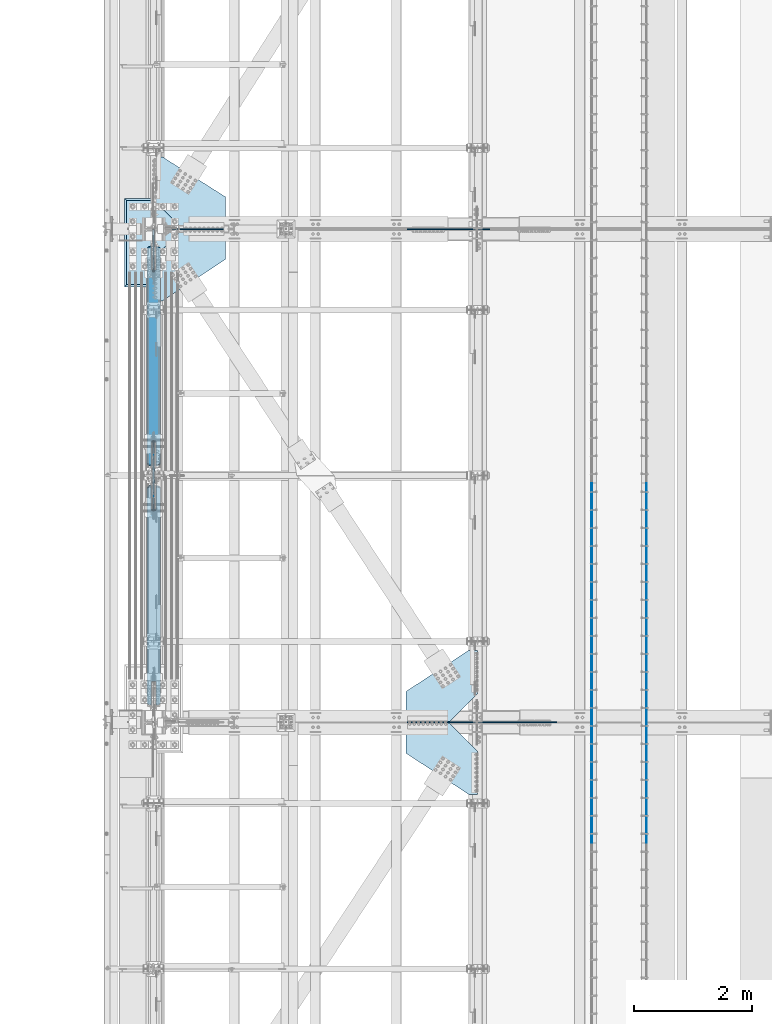
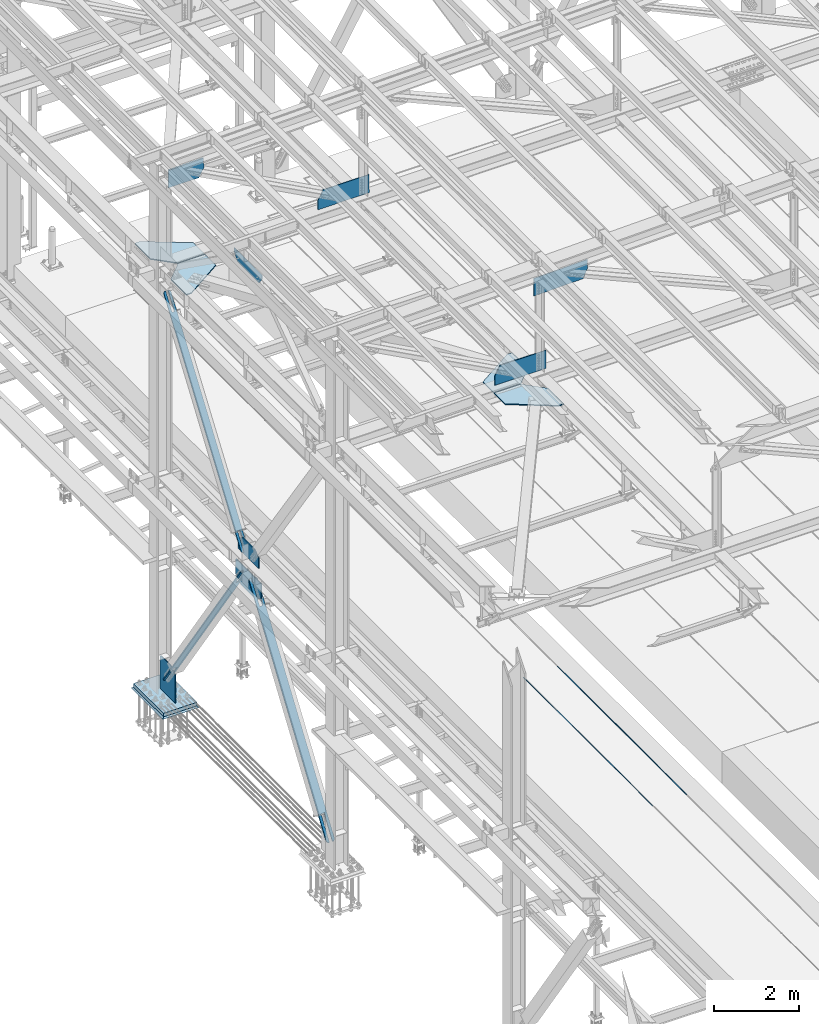
# One storey, part 2986 of 3843: 19 plates, 17 elements without a shape of their own.
"""IFC2X3 building model written with IfcOpenShell, lengths in millimetres."""

from ifc_helpers import new_model, si_unit, frame, origin_with_axes, place, context, subcontext, project, spatial, faceted_brep, material, type_object, element, aggregate, save


model = new_model("IFC2X3")

# Units and contexts
model_context = context("Model", 3, precision=1e-05, world=origin_with_axes())
body_context = subcontext(model_context, "Body", "Model", "MODEL_VIEW")
ifc_project = project(units=[si_unit("LENGTHUNIT", "METRE", prefix="MILLI"), si_unit("AREAUNIT", "SQUARE_METRE"), si_unit("VOLUMEUNIT", "CUBIC_METRE"), si_unit("MASSUNIT", "GRAM", prefix="KILO"), si_unit("TIMEUNIT", "SECOND"), si_unit("PLANEANGLEUNIT", "RADIAN"), si_unit("SOLIDANGLEUNIT", "STERADIAN"), si_unit("THERMODYNAMICTEMPERATUREUNIT", "DEGREE_CELSIUS"), si_unit("LUMINOUSINTENSITYUNIT", "LUMEN")], contexts=[model_context])

# Site, building, storey
site_placement = place(None, origin_with_axes())
site = spatial("IfcSite", under=ifc_project, at=site_placement, CompositionType="ELEMENT")
building_placement = place(site_placement, origin_with_axes())
building = spatial("IfcBuilding", under=site, at=building_placement, Name="Undefined", CompositionType="ELEMENT")
storey_placement = place(building_placement, origin_with_axes())
storey = spatial("IfcBuildingStorey", under=building, at=storey_placement, Name="Undefined", CompositionType="ELEMENT", Elevation=0.0)

# Assembly, plate
assembly_1_placement = place(storey_placement, origin_with_axes())
assembly_1 = element("IfcElementAssembly", 1, at=assembly_1_placement, inside=storey, Name="BEAM", AssemblyPlace="NOTDEFINED", PredefinedType="RIGID_FRAME")
ifc_material_1 = material(Name="STEEL/A572-50")
plate_type_1 = type_object("IfcPlateType", PredefinedType="NOTDEFINED")
plate_1_placement = place(assembly_1_placement, frame((42267.8821550224, 75628.4999999999, 42457.8407635457), z_axis=(-0.00436141699989823, 0.0, 0.999990488975647), x_axis=(-0.999990488975647, 0.0, -0.00436141699989637)))
plate_1 = element("IfcPlate", 2, at=plate_1_placement, type_object=plate_type_1, material=ifc_material_1, Name="PLATE", context=body_context, shape_type="Brep", body=[
    faceted_brep([(0.0, -9.52500000000146, 0.0), (-4.65661287307739e-10, -9.52499999999418, 523.259916225958), (-4.65661287307739e-10, 9.52499999999418, 523.259916225958), (0.0, 9.52500000000146, 0.0), (1253.01006209964, -9.52499999999418, 528.724867018755), (1253.01006209964, 9.52499999999418, 528.724867018755), (1398.4797275605, -9.52499999999418, 260.878609969819), (1398.4797275605, 9.52499999999418, 260.878609969819), (1398.47972756072, -9.52499999999418, 1.24418875202537e-09), (1398.47972756072, 9.52499999999418, 1.24418875202537e-09)], [[[0, 1, 2, 3]], [[1, 4, 5, 2]], [[4, 6, 7, 5]], [[6, 8, 9, 7]], [[8, 0, 3, 9]], [[5, 7, 9, 3, 2]], [[8, 6, 4, 1, 0]]]),
])
aggregate(assembly_1, [plate_1])

assembly_2_placement = place(storey_placement, origin_with_axes())
assembly_2 = element("IfcElementAssembly", 3, at=assembly_2_placement, inside=storey, Name="BEAM", AssemblyPlace="NOTDEFINED", PredefinedType="RIGID_FRAME")
plate_2_placement = place(assembly_2_placement, frame((42268.2788781144, 67271.8999999999, 42462.4013675577), z_axis=(-0.00512823099762316, 0.0, 0.999986850536963), x_axis=(-0.999986850536963, 0.0, -0.00512823099762594)))
plate_2 = element("IfcPlate", 4, at=plate_2_placement, type_object=plate_type_1, material=ifc_material_1, Name="PLATE", context=body_context, shape_type="Brep", body=[
    faceted_brep([(0.0, -9.52500000000146, 0.0), (-1.81171344593167e-09, -9.52499999999418, 522.378557665288), (-1.81171344593167e-09, 9.52499999999418, 522.378557665288), (0.0, 9.52500000000146, 0.0), (1253.19839036358, -9.52499999999418, 528.805333503253), (1253.19839036358, 9.52499999999418, 528.805333503253), (1398.70330577307, -9.52499999999418, 260.978224854669), (1398.70330577307, 9.52499999999418, 260.978224854669), (1398.70330577398, -9.52499999999418, 4.8748916015029e-09), (1398.70330577398, 9.52499999999418, 4.8748916015029e-09)], [[[0, 1, 2, 3]], [[1, 4, 5, 2]], [[4, 6, 7, 5]], [[6, 8, 9, 7]], [[8, 0, 3, 9]], [[5, 7, 9, 3, 2]], [[8, 6, 4, 1, 0]]]),
])
aggregate(assembly_2, [plate_2])

assembly_3_placement = place(storey_placement, origin_with_axes())
assembly_3 = element("IfcElementAssembly", 5, at=assembly_3_placement, inside=storey, Name="EMBED_ANGLE", AssemblyPlace="NOTDEFINED", PredefinedType="RIGID_FRAME")
ifc_material_2 = material(Name="STEEL/A36")
plate_type_2 = type_object("IfcPlateType", PredefinedType="NOTDEFINED")
plate_3_placement = place(assembly_3_placement, frame((44925.996, 71326.375, 30479.9999992371), z_axis=(0.0, -1.0, 0.0), x_axis=(0.0, 0.0, -1.0)))
plate_3 = element("IfcPlate", 6, at=plate_3_placement, type_object=plate_type_2, material=ifc_material_2, Name="PLATE", context=body_context, shape_type="Brep", body=[
    faceted_brep([(15.875, 1.58750000000146, 6096.0), (15.875, 1.58749999204883, -3.63797880709171e-12), (11.1125018504281, 6.35000000000582, -7.27595761418343e-12), (11.1124996186481, 6.34999999999854, 6096.0), (0.0, -6.3499999046162, 0.0), (3.81471181754023e-07, -6.34999999999854, 6096.0), (3.81471181754023e-07, 6.34999999999854, 6096.0), (7.27595761418343e-12, 6.3499999046162, 0.0), (15.875, -6.35000000000582, 3.63797880709171e-12), (15.875, -6.34999999999854, 6096.0)], [[[0, 1, 2, 3]], [[4, 5, 6, 7]], [[8, 9, 5, 4]], [[6, 5, 9, 0, 3]], [[7, 6, 3, 2]], [[8, 4, 7, 2, 1]], [[9, 8, 1, 0]]]),
])
aggregate(assembly_3, [plate_3])

assembly_4_placement = place(storey_placement, origin_with_axes())
assembly_4 = element("IfcElementAssembly", 7, at=assembly_4_placement, inside=storey, Name="EMBED_ANGLE", AssemblyPlace="NOTDEFINED", PredefinedType="RIGID_FRAME")
plate_4_placement = place(assembly_4_placement, frame((43998.896, 71326.375, 30479.9999996185), z_axis=(0.0, -1.0, 0.0), x_axis=(0.0, 0.0, -1.0)))
plate_4 = element("IfcPlate", 8, at=plate_4_placement, type_object=plate_type_2, material=ifc_material_2, Name="PLATE", context=body_context, shape_type="Brep", body=[
    faceted_brep([(15.8749946755343, -1.58750000000146, 6096.0), (11.1124999999702, -6.34999999999854, 6096.0), (11.1125001907349, -6.35000000006371, 0.0), (15.875, -1.58750000024156, -3.63797880709171e-12), (0.0, -6.3499999046162, 0.0), (3.81471181754023e-07, -6.34999999999854, 6096.0), (3.81471181754023e-07, 6.34999999999854, 6096.0), (7.27595761418343e-12, 6.3499999046162, 0.0), (15.875, 6.34999999999854, 6096.0), (15.875, 6.34999999999854, -3.63797880709171e-12)], [[[0, 1, 2, 3]], [[4, 5, 6, 7]], [[8, 9, 7, 6]], [[9, 8, 0, 3]], [[4, 7, 9, 3, 2]], [[5, 4, 2, 1]], [[8, 6, 5, 1, 0]]]),
])
aggregate(assembly_4, [plate_4])

assembly_5_placement = place(storey_placement, origin_with_axes())
assembly_5 = element("IfcElementAssembly", 9, at=assembly_5_placement, inside=storey, Name="CB", AssemblyPlace="NOTDEFINED", PredefinedType="RIGID_FRAME")
plate_type_3 = type_object("IfcPlateType", PredefinedType="NOTDEFINED")
plate_5_placement = place(assembly_5_placement, frame((36672.8375, 71627.7274739671, 36506.2328278227), z_axis=(0.0, 0.572746499261054, 0.819732546373637), x_axis=(-1.0, 0.0, 0.0)))
plate_5 = element("IfcPlate", 10, at=plate_5_placement, type_object=plate_type_3, material=ifc_material_2, Name="CB", context=body_context, shape_type="Brep", body=[
    faceted_brep([(0.0, -12.7000000001135, 65.0875015259007), (0.0, -12.7000000182597, 6401.59609690412), (0.0, 12.6999999816398, 6401.59609690415), (0.0, 12.6999999999025, 65.0875015259462), (4.95449104381987, -12.7000000183325, 6426.50400539227), (4.95449104381987, 12.6999999815671, 6426.50400539229), (19.0636878264413, -12.700000018398, 6447.61991060384), (19.0636878264413, 12.6999999815016, 6447.61991060387), (40.1795930378867, -12.7000000184344, 6461.72910738653), (40.1795930378867, 12.6999999814725, 6461.72910738658), (65.0875000000015, -12.7000000184344, 6466.68359843041), (65.0875000000015, 12.6999999814579, 6466.68359843042), (65.0875000000015, -12.7000000169282, 5935.26679923524), (65.0875000000015, 12.6999999829713, 5935.26679923527), (128.587500000001, -12.7000000169282, 5935.26679923524), (128.587500000001, 12.6999999829713, 5935.26679923527), (128.587498474124, -12.7000000184344, 6466.68359843041), (128.587498474124, 12.6999999814579, 6466.68359843042), (153.495406962116, -12.7000000184344, 6461.72910738653), (153.495406962116, 12.6999999814725, 6461.72910738658), (174.611312173562, -12.700000018398, 6447.61991060384), (174.611312173562, 12.6999999815016, 6447.61991060387), (188.720508956183, -12.7000000183325, 6426.50400539227), (188.720508956183, 12.6999999815671, 6426.50400539229), (193.675000000003, -12.7000000182597, 6401.59609690412), (193.675000000003, 12.6999999816398, 6401.59609690415), (193.674999999988, -12.7000000001135, 65.0875015259007), (193.674999999988, 12.6999999999025, 65.0875015259462), (188.720508956161, -12.7000000000698, 40.1795930378939), (188.720508956161, 12.6999999999389, 40.1795930379376), (174.611312173554, -12.7000000000407, 19.0636878264304), (174.611312173554, 12.6999999999753, 19.0636878264741), (153.495406962102, -12.7000000000189, 4.9544910438035), (153.495406962102, 12.7000000000044, 4.95449104384716), (128.587499999994, -12.7000000000044, -2.00088834390044e-11), (128.587499999994, 12.7000000000116, 1.81898940354586e-11), (128.587499999994, -12.6999999980762, 531.416799185412), (128.587499999994, 12.7000000018015, 531.416799185514), (65.0874999999942, -12.6999999980762, 531.416799185412), (65.0874999999942, 12.7000000018015, 531.416799185514), (65.0875015258789, -12.7000000000044, -2.00088834390044e-11), (65.0875015258789, 12.7000000000116, 1.81898940354586e-11), (40.1795930378867, -12.7000000000189, 4.9544910438035), (40.1795930378867, 12.7000000000044, 4.95449104384716), (19.063687826434, -12.7000000000407, 19.0636878264304), (19.063687826434, 12.6999999999753, 19.0636878264741), (4.95449104382715, -12.7000000000698, 40.1795930378939), (4.95449104382715, 12.6999999999389, 40.1795930379376)], [[[0, 1, 2, 3]], [[1, 4, 5, 2]], [[4, 6, 7, 5]], [[6, 8, 9, 7]], [[8, 10, 11, 9]], [[10, 12, 13, 11]], [[12, 14, 15, 13]], [[14, 16, 17, 15]], [[16, 18, 19, 17]], [[18, 20, 21, 19]], [[20, 22, 23, 21]], [[22, 24, 25, 23]], [[24, 26, 27, 25]], [[26, 28, 29, 27]], [[28, 30, 31, 29]], [[30, 32, 33, 31]], [[32, 34, 35, 33]], [[34, 36, 37, 35]], [[36, 38, 39, 37]], [[38, 40, 41, 39]], [[40, 42, 43, 41]], [[42, 44, 45, 43]], [[44, 46, 47, 45]], [[46, 0, 3, 47]], [[5, 7, 9, 11, 13, 15, 17, 19, 21, 23, 25, 27, 29, 31, 33, 35, 37, 39, 41, 43, 45, 47, 3, 2]], [[46, 44, 42, 40, 38, 36, 34, 32, 30, 28, 26, 24, 22, 20, 18, 16, 14, 12, 10, 8, 6, 4, 1, 0]]]),
])
aggregate(assembly_5, [plate_5])

assembly_6_placement = place(storey_placement, origin_with_axes())
assembly_6 = element("IfcElementAssembly", 11, at=assembly_6_placement, inside=storey, Name="BEAM", AssemblyPlace="NOTDEFINED", PredefinedType="RIGID_FRAME")
plate_type_4 = type_object("IfcPlateType", PredefinedType="NOTDEFINED")
plate_6_placement = place(assembly_6_placement, frame((36576.0, 70966.3007437756, 36436.3), z_axis=(0.0, 1.0, 0.0), x_axis=(0.0, 0.0, 1.0)))
plate_6 = element("IfcPlate", 12, at=plate_6_placement, type_object=plate_type_4, material=ifc_material_1, Name="CB", context=body_context, shape_type="Brep", body=[
    faceted_brep([(0.0, -12.6999999999971, 0.0), (0.0, -12.6999999999971, 967.798511309637), (0.0, 12.6999999999971, 967.798511309637), (0.0, 12.6999999999971, 0.0), (294.998228573058, -12.6999999999971, 967.798511309637), (294.998228573058, 12.6999999999971, 967.798511309637), (435.0204289799, -12.6999999999971, 767.394397034936), (435.0204289799, 12.6999999999971, 767.394397034936), (435.0204289799, -12.6999999999971, 490.249255654824), (435.0204289799, 12.6999999999971, 490.249255654824), (435.0204289799, -12.6999999999971, 200.404114274701), (435.0204289799, 12.6999999999971, 200.404114274701), (294.998228573058, -12.6999999999971, 0.0), (294.998228573058, 12.6999999999971, 0.0)], [[[0, 1, 2, 3]], [[1, 4, 5, 2]], [[4, 6, 7, 5]], [[6, 8, 9, 7]], [[8, 10, 11, 9]], [[10, 12, 13, 11]], [[12, 0, 3, 13]], [[5, 7, 9, 11, 13, 3, 2]], [[12, 10, 8, 6, 4, 1, 0]]]),
])

assembly_7_placement = place(storey_placement, origin_with_axes())
assembly_7 = element("IfcElementAssembly", 13, at=assembly_7_placement, inside=storey, Name="PLATE", AssemblyPlace="NOTDEFINED", PredefinedType="RIGID_FRAME")
plate_type_5 = type_object("IfcPlateType", PredefinedType="NOTDEFINED")
plate_7_placement = place(assembly_7_placement, frame((37058.6, 75635.6437499962, 42232.2646283724), z_axis=(0.0, 1.0, 0.0), x_axis=(1.0, 0.0, 0.0)))
plate_7 = element("IfcPlate", 14, at=plate_7_placement, type_object=plate_type_5, material=ifc_material_1, Name="PLATE", context=body_context, shape_type="Brep", body=[
    faceted_brep([(0.0, -14.2874999999985, 0.0), (-476.249999993554, -14.2874999999985, 475.456250073548), (-476.249999993554, 14.2874999999985, 475.456250073548), (0.0, 14.2874999999985, 0.0), (-476.249999993568, -14.2874999999985, 1212.05625003844), (-476.249999993568, 14.2874999999985, 1212.05625003844), (-327.025000000001, -14.2874999999985, 1212.05624999852), (-327.025000000001, 14.2874999999985, 1212.05624999852), (736.599999997721, -14.2874999999985, 536.379578847205), (736.599999997721, 14.2874999999985, 536.379578847205), (736.599999940488, -14.2874999999985, 0.0), (736.599999940488, 14.2874999999985, 0.0)], [[[0, 1, 2, 3]], [[1, 4, 5, 2]], [[4, 6, 7, 5]], [[6, 8, 9, 7]], [[8, 10, 11, 9]], [[10, 0, 3, 11]], [[5, 7, 9, 11, 3, 2]], [[10, 8, 6, 4, 1, 0]]]),
])
aggregate(assembly_7, [plate_7])

assembly_8_placement = place(storey_placement, origin_with_axes())
assembly_8 = element("IfcElementAssembly", 15, at=assembly_8_placement, inside=storey, Name="PLATE", AssemblyPlace="NOTDEFINED", PredefinedType="RIGID_FRAME")
plate_8_placement = place(assembly_8_placement, frame((36583.1437500007, 75145.9, 42232.2646283724), z_axis=(1.0, 0.0, 0.0), x_axis=(0.0, -1.0, 0.0)))
plate_8 = element("IfcPlate", 16, at=plate_8_placement, type_object=plate_type_5, material=ifc_material_1, Name="PLATE", context=body_context, shape_type="Brep", body=[
    faceted_brep([(0.0, -14.2874999999985, 0.0), (-475.456249998751, -14.2874999999985, 475.456249999283), (-475.456249998751, 14.2874999999985, 475.456249999283), (0.0, 14.2874999999985, 0.0), (-475.456249998751, -14.2874999999985, 1212.05624999934), (-475.456249998751, 14.2874999999985, 1212.05624999934), (28.9127655419579, -14.2874999999985, 1212.05624999934), (28.9127655419579, 14.2874999999985, 1212.05624999934), (736.600000000006, -14.2874999999985, 134.143749999275), (736.600000000006, 14.2874999999985, 134.143749999275), (736.599999940488, -14.2874999999985, 0.0), (736.599999940488, 14.2874999999985, 0.0)], [[[0, 1, 2, 3]], [[1, 4, 5, 2]], [[4, 6, 7, 5]], [[6, 8, 9, 7]], [[8, 10, 11, 9]], [[10, 0, 3, 11]], [[5, 7, 9, 11, 3, 2]], [[10, 8, 6, 4, 1, 0]]]),
])
aggregate(assembly_8, [plate_8])

assembly_9_placement = place(storey_placement, origin_with_axes())
assembly_9 = element("IfcElementAssembly", 17, at=assembly_9_placement, inside=storey, Name="BEAM", AssemblyPlace="NOTDEFINED", PredefinedType="RIGID_FRAME")
plate_type_6 = type_object("IfcPlateType", PredefinedType="NOTDEFINED")
plate_9_placement = place(assembly_9_placement, frame((36788.7250000031, 75628.5, 45030.6120725313), z_axis=(1.0, 0.0, 0.0), x_axis=(0.0, 0.0, -1.0)))
plate_9 = element("IfcPlate", 18, at=plate_9_placement, type_object=plate_type_6, material=ifc_material_1, Name="PLATE", context=body_context, shape_type="Brep", body=[
    faceted_brep([(3.17653907937347, 9.52499999999418, 0.0), (22.2331546521236, -9.52499999999418, 0.0), (-3.10184091063275, -9.52499999999418, 961.184688627131), (-22.1452261091399, 9.52499999999418, 960.682741306067), (270.962528215619, -9.52499999999418, 968.408502799248), (270.962528215619, 9.52499999999418, 968.408502799248), (517.067511415968, -9.52499999999418, 836.133417669531), (517.067511415968, 9.52499999999418, 836.133417669531), (517.067511415968, -9.52499999999418, 0.0), (517.067511415968, 9.52499999999418, 0.0)], [[[0, 1, 2, 3]], [[4, 5, 3, 2]], [[4, 6, 7, 5]], [[6, 8, 9, 7]], [[9, 8, 1, 0]], [[5, 7, 9, 0, 3]], [[8, 6, 4, 2, 1]]]),
])
aggregate(assembly_9, [plate_9])

assembly_10_placement = place(storey_placement, origin_with_axes())
assembly_10 = element("IfcElementAssembly", 19, at=assembly_10_placement, inside=storey, Name="PLATE", AssemblyPlace="NOTDEFINED", PredefinedType="RIGID_FRAME")
plate_type_7 = type_object("IfcPlateType", PredefinedType="NOTDEFINED")
plate_10_placement = place(assembly_10_placement, frame((41579.8, 67279.0437499999, 42232.2630004883), z_axis=(0.0, 1.0, 0.0), x_axis=(-1.0, 0.0, 0.0)))
plate_10 = element("IfcPlate", 20, at=plate_10_placement, type_object=plate_type_7, material=ifc_material_1, Name="PLATE", context=body_context, shape_type="Brep", body=[
    faceted_brep([(0.0, -14.2874999999985, 0.0), (-477.837500000001, -14.2874999999985, 475.456249999988), (-477.837500000001, 14.2874999999985, 475.456249999988), (0.0, 14.2874999999985, 0.0), (-477.837500000001, -14.2874999999985, 1212.05624999999), (-477.837500000001, 14.2874999999985, 1212.05624999999), (-330.200000000099, -14.2874999999985, 1212.05624999636), (-330.200000000099, 14.2874999999985, 1212.05624999636), (730.249999999854, -14.2874999999985, 515.833758773311), (730.249999999854, 14.2874999999985, 515.833758773311), (730.249999999854, -14.2874999999985, 2.91038304567337e-11), (730.249999999854, 14.2874999999985, 2.91038304567337e-11)], [[[0, 1, 2, 3]], [[1, 4, 5, 2]], [[4, 6, 7, 5]], [[6, 8, 9, 7]], [[8, 10, 11, 9]], [[10, 0, 3, 11]], [[5, 7, 9, 11, 3, 2]], [[10, 8, 6, 4, 1, 0]]]),
])
aggregate(assembly_10, [plate_10])

assembly_11_placement = place(storey_placement, origin_with_axes())
assembly_11 = element("IfcElementAssembly", 21, at=assembly_11_placement, inside=storey, Name="PLATE", AssemblyPlace="NOTDEFINED", PredefinedType="RIGID_FRAME")
plate_11_placement = place(assembly_11_placement, frame((41579.8, 67264.7562499999, 42232.2630004883), z_axis=(0.0, -1.0, 0.0), x_axis=(-1.0, 0.0, 0.0)))
plate_11 = element("IfcPlate", 22, at=plate_11_placement, type_object=plate_type_7, material=ifc_material_1, Name="PLATE", context=body_context, shape_type="Brep", body=[
    faceted_brep([(0.0, -14.2874999999985, 0.0), (-477.837500000001, -14.2874999999985, 475.456249999988), (-477.837500000001, 14.2874999999985, 475.456249999988), (0.0, 14.2874999999985, 0.0), (-477.837500000001, -14.2874999999985, 1212.05624999999), (-477.837500000001, 14.2874999999985, 1212.05624999999), (-330.200000000099, -14.2874999999985, 1212.05624999636), (-330.200000000099, 14.2874999999985, 1212.05624999636), (730.249999999854, -14.2874999999985, 515.833758773311), (730.249999999854, 14.2874999999985, 515.833758773311), (730.249999999854, -14.2874999999985, 2.91038304567337e-11), (730.249999999854, 14.2874999999985, 2.91038304567337e-11)], [[[0, 1, 2, 3]], [[1, 4, 5, 2]], [[4, 6, 7, 5]], [[6, 8, 9, 7]], [[8, 10, 11, 9]], [[10, 0, 3, 11]], [[5, 7, 9, 11, 3, 2]], [[10, 8, 6, 4, 1, 0]]]),
])
aggregate(assembly_11, [plate_11])

assembly_12_placement = place(storey_placement, origin_with_axes())
assembly_12 = element("IfcElementAssembly", 23, at=assembly_12_placement, inside=storey, Name="BEAM", AssemblyPlace="NOTDEFINED", PredefinedType="RIGID_FRAME")
plate_type_8 = type_object("IfcPlateType", PredefinedType="NOTDEFINED")
plate_12_placement = place(assembly_12_placement, frame((43395.4475779185, 67271.9, 45205.7794329168), z_axis=(0.0262138249906858, 0.0, -0.999656358644988), x_axis=(-0.999656358644988, 0.0, -0.0262138249906881)))
plate_12 = element("IfcPlate", 24, at=plate_12_placement, type_object=plate_type_8, material=ifc_material_1, Name="PLATE", context=body_context, shape_type="Brep", body=[
    faceted_brep([(0.0, -9.52500000000146, 0.0), (3.78349795937538e-10, -9.52499999999418, 234.434178541473), (3.78349795937538e-10, 9.52499999999418, 234.434178541473), (0.0, 9.52500000000146, 0.0), (130.338354888743, -9.52499999999418, 509.960862927524), (130.338354888743, 9.52499999999418, 509.960862927524), (1473.92210353963, -9.52499999999418, 509.960862925349), (1473.92210353963, 9.52499999999418, 509.960862925349), (1460.54948314359, -9.52499999999418, -2.39379005506635e-09), (1460.54948314359, 9.52499999999418, -2.39379005506635e-09)], [[[0, 1, 2, 3]], [[1, 4, 5, 2]], [[4, 6, 7, 5]], [[6, 8, 9, 7]], [[8, 0, 3, 9]], [[5, 7, 9, 3, 2]], [[8, 6, 4, 1, 0]]]),
])
aggregate(assembly_12, [plate_12])

assembly_13_placement = place(storey_placement, origin_with_axes())
assembly_13 = element("IfcElementAssembly", 25, at=assembly_13_placement, inside=storey, Name="COLUMN", AssemblyPlace="NOTDEFINED", PredefinedType="RIGID_FRAME")
plate_type_9 = type_object("IfcPlateType", PredefinedType="NOTDEFINED")
plate_13_placement = place(assembly_13_placement, frame((36576.0, 75615.8, 30162.5), z_axis=(0.0, 0.0, 1.0), x_axis=(0.0, -1.0, 0.0)))
plate_13 = element("IfcPlate", 26, at=plate_13_placement, type_object=plate_type_9, material=ifc_material_1, Name="CB", context=body_context, shape_type="Brep", body=[
    faceted_brep([(0.0, -12.6999999999971, 19.0499992370605), (0.0, -12.6999999999971, 942.254570209607), (0.0, 12.6999999999971, 942.254570209607), (0.0, 12.6999999999971, 19.0499992370605), (19.0499992370605, -12.6999999999971, 961.304569446667), (19.0499992370605, 12.6999999999971, 961.304569446667), (477.459274804351, -12.6999999999971, 961.304569446667), (477.459274804351, 12.6999999999971, 961.304569446667), (707.843688003049, -12.6999999999971, 803.230592603264), (707.843688003049, 12.6999999999971, 803.230592603264), (707.843688003049, -12.6999999999971, 0.0), (707.843688003049, 12.6999999999971, 0.0), (19.0500015258731, -12.6999999999971, -6.33008312433958e-10), (19.0500015258731, 12.6999999999971, 0.0)], [[[0, 1, 2, 3]], [[1, 4, 5, 2]], [[4, 6, 7, 5]], [[6, 8, 9, 7]], [[8, 10, 11, 9]], [[10, 12, 13, 11]], [[12, 0, 3, 13]], [[5, 7, 9, 11, 13, 3, 2]], [[12, 10, 8, 6, 4, 1, 0]]]),
])

# Plate
plate_type_10 = type_object("IfcPlateType", PredefinedType="NOTDEFINED")
plate_14_placement = place(assembly_6_placement, frame((36576.0, 70855.2795924979, 35632.0086563323), z_axis=(0.0, 1.0, 0.0), x_axis=(0.0, 0.0, 1.0)))
plate_14 = element("IfcPlate", 27, at=plate_14_placement, type_object=plate_type_10, material=ifc_material_1, Name="CB", context=body_context, shape_type="Brep", body=[
    faceted_brep([(0.0, -12.6999999999971, 0.0), (-158.073978181652, -12.6999999999971, 230.384415149136), (-158.073978181652, 12.6999999999971, 230.384415149136), (0.0, 12.6999999999971, 0.0), (-158.073978181652, -12.6999999999971, 601.270406193056), (-158.073978181652, 12.6999999999971, 601.270406193056), (-158.073978181652, -12.6999999999971, 959.456399904215), (-158.073978181652, 12.6999999999971, 959.456399904215), (-1.33824505610391e-06, -12.6999999999971, 1189.84081310291), (-1.33824505610391e-06, 12.6999999999971, 1189.84081310291), (435.991343667716, -12.6999999999971, 1189.84081310291), (435.991343667716, 12.6999999999971, 1189.84081310291), (435.991343667716, 12.6999999999971, 0.0), (435.991343667716, -12.6999999999971, 0.0)], [[[0, 1, 2, 3]], [[1, 4, 5, 2]], [[4, 6, 7, 5]], [[6, 8, 9, 7]], [[9, 8, 10, 11]], [[3, 2, 5, 7, 9, 11, 12]], [[0, 3, 12, 13]], [[8, 6, 4, 1, 0, 13, 10]], [[12, 11, 10, 13]]]),
])

aggregate(assembly_6, [plate_6, plate_14])

# Assembly, plate
assembly_14_placement = place(storey_placement, origin_with_axes())
assembly_14 = element("IfcElementAssembly", 28, at=assembly_14_placement, inside=storey, Name="CB", AssemblyPlace="NOTDEFINED", PredefinedType="RIGID_FRAME")
plate_type_11 = type_object("IfcPlateType", PredefinedType="NOTDEFINED")
plate_15_placement = place(assembly_14_placement, frame((36461.7, 75326.3047308368, 30602.9335267629), z_axis=(0.0, -0.565762265008601, 0.824568408012542), x_axis=(1.0, 0.0, 0.0)))
plate_15 = element("IfcPlate", 29, at=plate_15_placement, type_object=plate_type_11, material=ifc_material_2, Name="CB", context=body_context, shape_type="Brep", body=[
    faceted_brep([(0.0, -15.8749999996799, 73.0250015258098), (0.0, -15.8749999668507, 6465.9984944254), (0.0, 15.8750000332511, 6465.99849442527), (0.0, 15.875000000422, 73.0250015256788), (5.55869725451339, -15.8749999667052, 6493.94395265774), (5.55869725451339, 15.8750000333966, 6493.94395265761), (21.3885277507725, -15.8749999665888, 6517.63496820041), (21.3885277507725, 15.8750000335131, 6517.63496820028), (45.0795432934901, -15.874999966516, 6533.46479869664), (45.0795432934901, 15.8750000335858, 6533.46479869651), (73.0250000000015, -15.8749999664869, 6539.02349595114), (73.0250000000015, 15.8750000336149, 6539.02349595101), (73.0250000000015, -15.8749999701104, 5831.73674794907), (73.0250000000015, 15.8750000299915, 5831.73674794894), (155.575000000004, -15.8749999701104, 5831.73674794907), (155.575000000004, 15.8750000299915, 5831.73674794894), (155.574998474127, -15.8749999664869, 6539.02349595114), (155.574998474127, 15.8750000336149, 6539.02349595101), (183.520456706516, -15.874999966516, 6533.46479869664), (183.520456706516, 15.8750000335858, 6533.46479869651), (207.211472249233, -15.8749999665888, 6517.63496820041), (207.211472249233, 15.8750000335131, 6517.63496820028), (223.041302745492, -15.8749999667052, 6493.94395265774), (223.041302745492, 15.8750000333966, 6493.94395265761), (228.600000000006, -15.8749999668507, 6465.9984944254), (228.600000000006, 15.8750000332511, 6465.99849442527), (228.600000000006, -15.8749999996799, 73.0250015258098), (228.600000000006, 15.875000000422, 73.0250015256788), (223.041302745492, -15.8749999998254, 45.0795432934756), (223.041302745492, 15.8750000002765, 45.0795432933373), (207.211472249233, -15.8749999999563, 21.3885277508089), (207.211472249233, 15.8750000001455, 21.3885277506743), (183.520456706516, -15.8750000000291, 5.55869725457887), (183.520456706516, 15.8750000000728, 5.55869725444427), (155.575000000004, -15.8750000000437, 6.54836185276508e-11), (155.574999999975, 15.875, 0.0), (155.575000000004, -15.8749999964202, 707.286748002138), (155.575000000004, 15.8750000036671, 707.286748002003), (73.0250000000015, -15.8749999964202, 707.286748002138), (73.0250000000015, 15.8750000036671, 707.286748002003), (73.0250015258789, -15.8750000000437, 6.54836185276508e-11), (73.0250015258789, 15.8750000000437, -6.18456397205591e-11), (45.0795432934901, -15.8750000000291, 5.55869725457887), (45.0795432934901, 15.8750000000728, 5.55869725444427), (21.3885277507725, -15.8749999999563, 21.3885277508089), (21.3885277507725, 15.8750000001455, 21.3885277506743), (5.55869725451339, -15.8749999998254, 45.0795432934756), (5.55869725451339, 15.8750000002765, 45.0795432933373)], [[[0, 1, 2, 3]], [[1, 4, 5, 2]], [[4, 6, 7, 5]], [[6, 8, 9, 7]], [[8, 10, 11, 9]], [[10, 12, 13, 11]], [[12, 14, 15, 13]], [[14, 16, 17, 15]], [[16, 18, 19, 17]], [[18, 20, 21, 19]], [[20, 22, 23, 21]], [[22, 24, 25, 23]], [[24, 26, 27, 25]], [[26, 28, 29, 27]], [[28, 30, 31, 29]], [[30, 32, 33, 31]], [[32, 34, 35, 33]], [[34, 36, 37, 35]], [[36, 38, 39, 37]], [[38, 40, 41, 39]], [[40, 42, 43, 41]], [[42, 44, 45, 43]], [[44, 46, 47, 45]], [[46, 0, 3, 47]], [[5, 7, 9, 11, 13, 15, 17, 19, 21, 23, 25, 27, 29, 31, 33, 35, 37, 39, 41, 43, 45, 47, 3, 2]], [[46, 44, 42, 40, 38, 36, 34, 32, 30, 28, 26, 24, 22, 20, 18, 16, 14, 12, 10, 8, 6, 4, 1, 0]]]),
])
aggregate(assembly_14, [plate_15])

assembly_15_placement = place(storey_placement, origin_with_axes())
assembly_15 = element("IfcElementAssembly", 30, at=assembly_15_placement, inside=storey, Name="CB", AssemblyPlace="NOTDEFINED", PredefinedType="RIGID_FRAME")
plate_16_placement = place(assembly_15_placement, frame((36690.3, 67574.095267285, 30602.9335280854), z_axis=(0.0, 0.5657622650086, 0.824568408012542), x_axis=(-1.0, 0.0, 0.0)))
plate_16 = element("IfcPlate", 31, at=plate_16_placement, type_object=plate_type_11, material=ifc_material_2, Name="CB", context=body_context, shape_type="Brep", body=[
    faceted_brep([(0.0, -15.8749999996799, 73.0250015258098), (0.0, -15.8749999668507, 6465.9984944254), (0.0, 15.8750000332511, 6465.99849442527), (0.0, 15.875000000422, 73.0250015256788), (5.55869725451339, -15.8749999667052, 6493.94395265774), (5.55869725451339, 15.8750000333966, 6493.94395265761), (21.3885277507725, -15.8749999665888, 6517.63496820041), (21.3885277507725, 15.8750000335131, 6517.63496820028), (45.0795432934901, -15.874999966516, 6533.46479869664), (45.0795432934901, 15.8750000335858, 6533.46479869651), (73.0250000000015, -15.8749999664869, 6539.02349595114), (73.0250000000015, 15.8750000336149, 6539.02349595101), (73.0250000000015, -15.8749999701104, 5831.73674794907), (73.0250000000015, 15.8750000299915, 5831.73674794894), (155.575000000004, -15.8749999701104, 5831.73674794907), (155.575000000004, 15.8750000299915, 5831.73674794894), (155.574998474127, -15.8749999664869, 6539.02349595114), (155.574998474127, 15.8750000336149, 6539.02349595101), (183.520456706516, -15.874999966516, 6533.46479869664), (183.520456706516, 15.8750000335858, 6533.46479869651), (207.211472249233, -15.8749999665888, 6517.63496820041), (207.211472249233, 15.8750000335131, 6517.63496820028), (223.041302745492, -15.8749999667052, 6493.94395265774), (223.041302745492, 15.8750000333966, 6493.94395265761), (228.600000000006, -15.8749999668507, 6465.9984944254), (228.600000000006, 15.8750000332511, 6465.99849442527), (228.600000000006, -15.8749999996799, 73.0250015258098), (228.600000000006, 15.875000000422, 73.0250015256788), (223.041302745492, -15.8749999998254, 45.0795432934756), (223.041302745492, 15.8750000002765, 45.0795432933373), (207.211472249233, -15.8749999999563, 21.3885277508089), (207.211472249233, 15.8750000001455, 21.3885277506743), (183.520456706516, -15.8750000000291, 5.55869725457887), (183.520456706516, 15.8750000000728, 5.55869725444427), (155.575000000004, -15.8750000000437, 6.54836185276508e-11), (155.574999999975, 15.875, 0.0), (155.575000000004, -15.8749999964202, 707.286748002138), (155.575000000004, 15.8750000036671, 707.286748002003), (73.0250000000015, -15.8749999964202, 707.286748002138), (73.0250000000015, 15.8750000036671, 707.286748002003), (73.0250015258789, -15.8750000000437, 6.54836185276508e-11), (73.0250015258789, 15.8750000000437, -6.18456397205591e-11), (45.0795432934901, -15.8750000000291, 5.55869725457887), (45.0795432934901, 15.8750000000728, 5.55869725444427), (21.3885277507725, -15.8749999999563, 21.3885277508089), (21.3885277507725, 15.8750000001455, 21.3885277506743), (5.55869725451339, -15.8749999998254, 45.0795432934756), (5.55869725451339, 15.8750000002765, 45.0795432933373)], [[[0, 1, 2, 3]], [[1, 4, 5, 2]], [[4, 6, 7, 5]], [[6, 8, 9, 7]], [[8, 10, 11, 9]], [[10, 12, 13, 11]], [[12, 14, 15, 13]], [[14, 16, 17, 15]], [[16, 18, 19, 17]], [[18, 20, 21, 19]], [[20, 22, 23, 21]], [[22, 24, 25, 23]], [[24, 26, 27, 25]], [[26, 28, 29, 27]], [[28, 30, 31, 29]], [[30, 32, 33, 31]], [[32, 34, 35, 33]], [[34, 36, 37, 35]], [[36, 38, 39, 37]], [[38, 40, 41, 39]], [[40, 42, 43, 41]], [[42, 44, 45, 43]], [[44, 46, 47, 45]], [[46, 0, 3, 47]], [[5, 7, 9, 11, 13, 15, 17, 19, 21, 23, 25, 27, 29, 31, 33, 35, 37, 39, 41, 43, 45, 47, 3, 2]], [[46, 44, 42, 40, 38, 36, 34, 32, 30, 28, 26, 24, 22, 20, 18, 16, 14, 12, 10, 8, 6, 4, 1, 0]]]),
])
aggregate(assembly_15, [plate_16])

assembly_16_placement = place(storey_placement, origin_with_axes())
assembly_16 = element("IfcElementAssembly", 32, at=assembly_16_placement, inside=storey, Name="BEAM", AssemblyPlace="NOTDEFINED", PredefinedType="RIGID_FRAME")
plate_type_12 = type_object("IfcPlateType", PredefinedType="NOTDEFINED")
plate_17_placement = place(assembly_16_placement, frame((36563.2999999316, 72112.1786729324, 45002.4500000025), z_axis=(0.0, 0.0, -1.0), x_axis=(0.0, -1.0, 0.0)))
plate_17 = element("IfcPlate", 33, at=plate_17_placement, type_object=plate_type_12, material=ifc_material_1, context=body_context, shape_type="Brep", body=[
    faceted_brep([(0.0, -6.3499999046162, 0.0), (0.0, -6.34999999999854, 107.914709618752), (0.0, 6.34999999999854, 107.914709618752), (7.27595761418343e-12, 6.3499999046162, 0.0), (147.42628116945, -6.34999999999854, 314.75158162311), (147.42628116945, 6.34999999999854, 314.75158162311), (1176.5310664634, -6.34999999999854, 314.75158162311), (1176.5310664634, 6.34999999999854, 314.75158162311), (1323.95734763292, -6.34999999999854, 107.914709617915), (1323.95734763292, 6.34999999999854, 107.914709617915), (1323.95734763292, -6.34999999999854, 0.0), (1323.95734763292, 6.34999999999854, 0.0)], [[[0, 1, 2, 3]], [[1, 4, 5, 2]], [[4, 6, 7, 5]], [[6, 8, 9, 7]], [[8, 10, 11, 9]], [[10, 0, 3, 11]], [[5, 7, 9, 11, 3, 2]], [[10, 8, 6, 4, 1, 0]]]),
])
aggregate(assembly_16, [plate_17])

assembly_17_placement = place(storey_placement, origin_with_axes())
assembly_17 = element("IfcElementAssembly", 34, at=assembly_17_placement, inside=storey, Name="GROUT", AssemblyPlace="NOTDEFINED", PredefinedType="REINFORCEMENT_UNIT")
ifc_material_3 = material(Name="CONCRETE/Concrete_Undefined")
plate_type_13 = type_object("IfcPlateType", PredefinedType="NOTDEFINED")
plate_18_placement = place(assembly_17_placement, frame((36080.7, 74650.6, 30041.85), z_axis=(0.0, 1.0, 0.0), x_axis=(1.0, 0.0, 0.0)))
plate_18 = element("IfcPlate", 35, at=plate_18_placement, type_object=plate_type_13, material=ifc_material_3, Name="GROUT", context=body_context, shape_type="Brep", body=[
    faceted_brep([(38.0999999997948, -19.0499999997955, 1460.49999999932), (0.0, 19.0499999999993, 1498.59997558594), (0.0, 19.0500000000029, 0.0), (38.1000000006916, -19.0499999999811, 38.1000000006607), (952.500000000204, -19.0499999998101, 38.1000000006607), (990.599975585938, 19.0499999999993, 0.0), (990.599975585938, 19.0499999999993, 1498.59997558594), (952.500000000204, -19.0499999999956, 1460.49999999932)], [[[0, 1, 2, 3]], [[4, 5, 6, 7]], [[4, 7, 0, 3]], [[5, 4, 3, 2]], [[6, 5, 2, 1]], [[7, 6, 1, 0]]]),
])
aggregate(assembly_17, [plate_18])

# Plate
plate_type_14 = type_object("IfcPlateType", PredefinedType="NOTDEFINED")
plate_19_placement = place(assembly_13_placement, frame((36118.8, 74688.7, 30111.7), z_axis=(0.0, 1.0, 0.0), x_axis=(1.0, 0.0, 0.0)))
plate_19 = element("IfcPlate", 36, at=plate_19_placement, type_object=plate_type_14, material=ifc_material_1, Name="PLATE", context=body_context, shape_type="Brep", body=[
    faceted_brep([(0.0, -50.7999999999993, 0.0), (0.0, -50.7999999999993, 1422.40002441406), (0.0, 50.7999999999993, 1422.40002441406), (0.0, 50.7999999999993, 0.0), (914.400024414062, -50.7999999999993, 1422.40002441406), (914.400024414062, 50.7999999999993, 1422.40002441406), (914.400024414062, -50.7999999999993, 0.0), (914.400024414062, 50.7999999999993, 0.0)], [[[0, 1, 2, 3]], [[1, 4, 5, 2]], [[4, 6, 7, 5]], [[6, 0, 3, 7]], [[5, 7, 3, 2]], [[6, 4, 1, 0]]]),
])

aggregate(assembly_13, [plate_13, plate_19])

save(model, "model.ifc")
